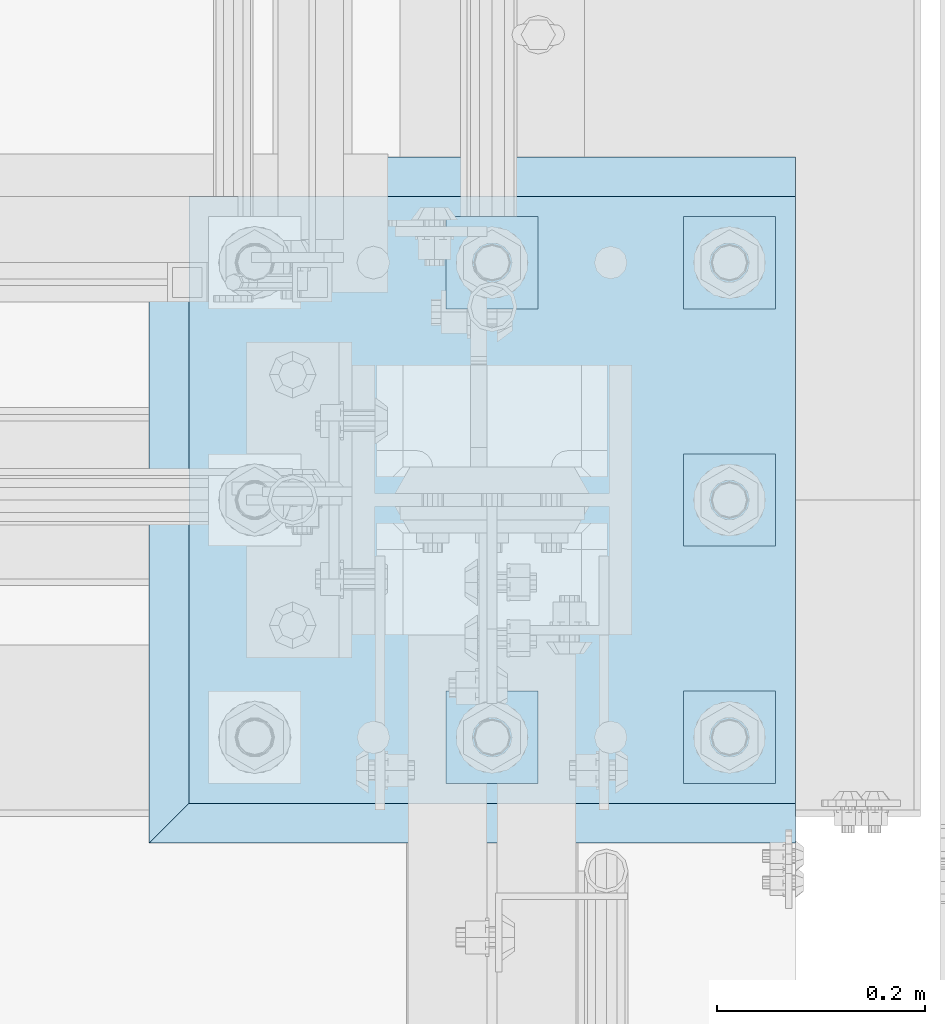
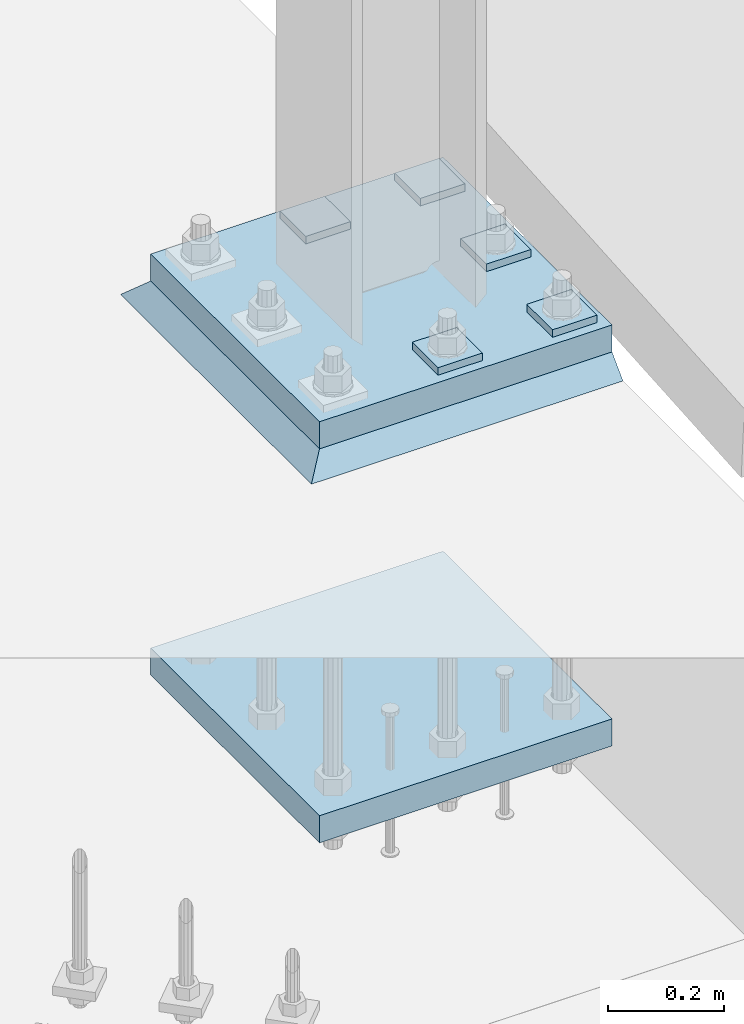
# One storey, part 1522 of 1876: 8 plates, 3 elements without a shape of their own.
"""IFC2X3 building model written with IfcOpenShell, lengths in millimetres."""

from ifc_helpers import new_model, si_unit, frame, origin_with_axes, place, context, subcontext, project, spatial, faceted_brep, material, type_object, element, aggregate, save


model = new_model("IFC2X3")

# Units and contexts
model_context = context("Model", 3, precision=1e-05, world=origin_with_axes())
body_context = subcontext(model_context, "Body", "Model", "MODEL_VIEW")
ifc_project = project(units=[si_unit("LENGTHUNIT", "METRE", prefix="MILLI"), si_unit("AREAUNIT", "SQUARE_METRE"), si_unit("VOLUMEUNIT", "CUBIC_METRE"), si_unit("MASSUNIT", "GRAM", prefix="KILO"), si_unit("TIMEUNIT", "SECOND"), si_unit("PLANEANGLEUNIT", "RADIAN"), si_unit("SOLIDANGLEUNIT", "STERADIAN"), si_unit("THERMODYNAMICTEMPERATUREUNIT", "DEGREE_CELSIUS"), si_unit("LUMINOUSINTENSITYUNIT", "LUMEN")], contexts=[model_context])

# Site, building, storey
site_placement = place(None, origin_with_axes())
site = spatial("IfcSite", under=ifc_project, at=site_placement, CompositionType="ELEMENT")
building_placement = place(site_placement, origin_with_axes())
building = spatial("IfcBuilding", under=site, at=building_placement, Name="Undefined", CompositionType="ELEMENT")
storey_placement = place(building_placement, origin_with_axes())
storey = spatial("IfcBuildingStorey", under=building, at=storey_placement, Name="Undefined", CompositionType="ELEMENT", Elevation=0.0)

# Assembly, plate
assembly_1_placement = place(storey_placement, origin_with_axes())
assembly_1 = element("IfcElementAssembly", 1, at=assembly_1_placement, inside=storey, Name="TEMPLATE", AssemblyPlace="NOTDEFINED", PredefinedType="RIGID_FRAME")
ifc_material_1 = material(Name="STEEL/A572-50")
plate_type_1 = type_object("IfcPlateType", PredefinedType="NOTDEFINED")
plate_1_placement = place(assembly_1_placement, frame((7327.9, -7404.1, -765.175), z_axis=(0.0, 1.0, 0.0), x_axis=(1.0, 0.0, 0.0)))
plate_1 = element("IfcPlate", 2, at=plate_1_placement, type_object=plate_type_1, material=ifc_material_1, Name="PLATE", context=body_context, shape_type="Brep", body=[
    faceted_brep([(0.0, -28.575, 0.0), (0.0, -28.575, 584.200012207031), (0.0, 28.575, 584.200012207031), (0.0, 28.575, 0.0), (584.200012207031, -28.575, 584.200012207031), (584.200012207031, 28.575, 584.200012207031), (584.200012207031, -28.575, 0.0), (584.200012207031, 28.575, 0.0)], [[[0, 1, 2, 3]], [[1, 4, 5, 2]], [[4, 6, 7, 5]], [[6, 0, 3, 7]], [[5, 7, 3, 2]], [[6, 4, 1, 0]]]),
])

assembly_2_placement = place(storey_placement, origin_with_axes())
assembly_2 = element("IfcElementAssembly", 3, at=assembly_2_placement, inside=storey, Name="COLUMN", AssemblyPlace="NOTDEFINED", PredefinedType="RIGID_FRAME")
ifc_material_2 = material(Name="STEEL/A572-GR.50")
plate_2_placement = place(assembly_2_placement, frame((7327.9, -7404.1, 66.675), z_axis=(0.0, 1.0, 0.0), x_axis=(1.0, 0.0, 0.0)))
plate_2 = element("IfcPlate", 4, at=plate_2_placement, type_object=plate_type_1, material=ifc_material_2, Name="PLATE", context=body_context, shape_type="Brep", body=[
    faceted_brep([(0.0, -28.575, 0.0), (0.0, -28.575, 584.200012207031), (0.0, 28.575, 584.200012207031), (0.0, 28.575, 0.0), (584.200012207031, -28.575, 584.200012207031), (584.200012207031, 28.575, 584.200012207031), (584.200012207031, -28.575, 0.0), (584.200012207031, 28.575, 0.0)], [[[0, 1, 2, 3]], [[1, 4, 5, 2]], [[4, 6, 7, 5]], [[6, 0, 3, 7]], [[5, 7, 3, 2]], [[6, 4, 1, 0]]]),
])
aggregate(assembly_2, [plate_2])

# Plate
plate_type_2 = type_object("IfcPlateType", PredefinedType="NOTDEFINED")
plate_3_placement = place(assembly_1_placement, frame((7804.15, -7296.15, 103.1875), z_axis=(0.0, -1.0, 0.0), x_axis=(1.0, 0.0, 0.0)))
plate_3 = element("IfcPlate", 5, at=plate_3_placement, type_object=plate_type_2, material=ifc_material_1, Name="PLATE WASHER", context=body_context, shape_type="Brep", body=[
    faceted_brep([(0.0, -7.9375, 0.0), (0.0, -7.9375, 88.9000015258789), (0.0, 7.9375, 88.9000015258789), (0.0, 7.9375, 0.0), (88.9000015258789, -7.9375, 88.9000015258789), (88.9000015258789, 7.9375, 88.9000015258789), (88.9000015258789, -7.9375, 0.0), (88.9000015258789, 7.9375, 0.0)], [[[0, 1, 2, 3]], [[1, 4, 5, 2]], [[4, 6, 7, 5]], [[6, 0, 3, 7]], [[5, 7, 3, 2]], [[6, 4, 1, 0]]]),
])

plate_4_placement = place(assembly_1_placement, frame((7804.15, -7067.55, 103.1875), z_axis=(0.0, -1.0, 0.0), x_axis=(1.0, 0.0, 0.0)))
plate_4 = element("IfcPlate", 6, at=plate_4_placement, type_object=plate_type_2, material=ifc_material_1, Name="PLATE WASHER", context=body_context, shape_type="Brep", body=[
    faceted_brep([(0.0, -7.9375, 0.0), (0.0, -7.9375, 88.9000015258789), (0.0, 7.9375, 88.9000015258789), (0.0, 7.9375, 0.0), (88.9000015258789, -7.9375, 88.9000015258789), (88.9000015258789, 7.9375, 88.9000015258789), (88.9000015258789, -7.9375, 0.0), (88.9000015258789, 7.9375, 0.0)], [[[0, 1, 2, 3]], [[1, 4, 5, 2]], [[4, 6, 7, 5]], [[6, 0, 3, 7]], [[5, 7, 3, 2]], [[6, 4, 1, 0]]]),
])

plate_5_placement = place(assembly_1_placement, frame((7804.15, -6838.95, 103.1875), z_axis=(0.0, -1.0, 0.0), x_axis=(1.0, 0.0, 0.0)))
plate_5 = element("IfcPlate", 7, at=plate_5_placement, type_object=plate_type_2, material=ifc_material_1, Name="PLATE WASHER", context=body_context, shape_type="Brep", body=[
    faceted_brep([(0.0, -7.9375, 0.0), (0.0, -7.9375, 88.9000015258789), (0.0, 7.9375, 88.9000015258789), (0.0, 7.9375, 0.0), (88.9000015258789, -7.9375, 88.9000015258789), (88.9000015258789, 7.9375, 88.9000015258789), (88.9000015258789, -7.9375, 0.0), (88.9000015258789, 7.9375, 0.0)], [[[0, 1, 2, 3]], [[1, 4, 5, 2]], [[4, 6, 7, 5]], [[6, 0, 3, 7]], [[5, 7, 3, 2]], [[6, 4, 1, 0]]]),
])

plate_6_placement = place(assembly_1_placement, frame((7575.55, -7296.15, 103.1875), z_axis=(0.0, -1.0, 0.0), x_axis=(1.0, 0.0, 0.0)))
plate_6 = element("IfcPlate", 8, at=plate_6_placement, type_object=plate_type_2, material=ifc_material_1, Name="PLATE WASHER", context=body_context, shape_type="Brep", body=[
    faceted_brep([(0.0, -7.9375, 0.0), (0.0, -7.9375, 88.9000015258789), (0.0, 7.9375, 88.9000015258789), (0.0, 7.9375, 0.0), (88.9000015258789, -7.9375, 88.9000015258789), (88.9000015258789, 7.9375, 88.9000015258789), (88.9000015258789, -7.9375, 0.0), (88.9000015258789, 7.9375, 0.0)], [[[0, 1, 2, 3]], [[1, 4, 5, 2]], [[4, 6, 7, 5]], [[6, 0, 3, 7]], [[5, 7, 3, 2]], [[6, 4, 1, 0]]]),
])

plate_7_placement = place(assembly_1_placement, frame((7575.55, -6838.95, 103.1875), z_axis=(0.0, -1.0, 0.0), x_axis=(1.0, 0.0, 0.0)))
plate_7 = element("IfcPlate", 9, at=plate_7_placement, type_object=plate_type_2, material=ifc_material_1, Name="PLATE WASHER", context=body_context, shape_type="Brep", body=[
    faceted_brep([(0.0, -7.9375, 0.0), (0.0, -7.9375, 88.9000015258789), (0.0, 7.9375, 88.9000015258789), (0.0, 7.9375, 0.0), (88.9000015258789, -7.9375, 88.9000015258789), (88.9000015258789, 7.9375, 88.9000015258789), (88.9000015258789, -7.9375, 0.0), (88.9000015258789, 7.9375, 0.0)], [[[0, 1, 2, 3]], [[1, 4, 5, 2]], [[4, 6, 7, 5]], [[6, 0, 3, 7]], [[5, 7, 3, 2]], [[6, 4, 1, 0]]]),
])

aggregate(assembly_1, [plate_1, plate_3, plate_4, plate_5, plate_6, plate_7])

# Assembly, plate
assembly_3_placement = place(storey_placement, origin_with_axes())
assembly_3 = element("IfcElementAssembly", 10, at=assembly_3_placement, inside=storey, Name="GROUT", AssemblyPlace="NOTDEFINED", PredefinedType="REINFORCEMENT_UNIT")
ifc_material_3 = material(Name="CONCRETE/Concrete_Undefined")
plate_type_3 = type_object("IfcPlateType", PredefinedType="NOTDEFINED")
plate_8_placement = place(assembly_3_placement, frame((7289.8, -7442.2, 19.05), z_axis=(0.0, 1.0, 0.0), x_axis=(1.0, 0.0, 0.0)))
plate_8 = element("IfcPlate", 11, at=plate_8_placement, type_object=plate_type_3, material=ifc_material_3, Name="GROUT", context=body_context, shape_type="Brep", body=[
    faceted_brep([(622.299804676334, 19.0499984735558, 660.400024414062), (622.299999999984, -19.05, 622.299999999983), (622.299999999984, -19.05, 38.1000000000167), (622.299804676334, 19.05, 0.0), (38.0999999999849, -19.05, 622.299999999983), (0.0, 19.05, 660.400024414062), (-9.09494701772928e-13, 19.05, -1.81898940354586e-12), (38.1000000120275, -19.05, 38.1000000109725)], [[[0, 1, 2, 3]], [[4, 5, 6, 7]], [[6, 5, 0, 3]], [[7, 6, 3, 2]], [[2, 1, 4, 7]], [[5, 4, 1, 0]]]),
])
aggregate(assembly_3, [plate_8])

save(model, "model.ifc")
